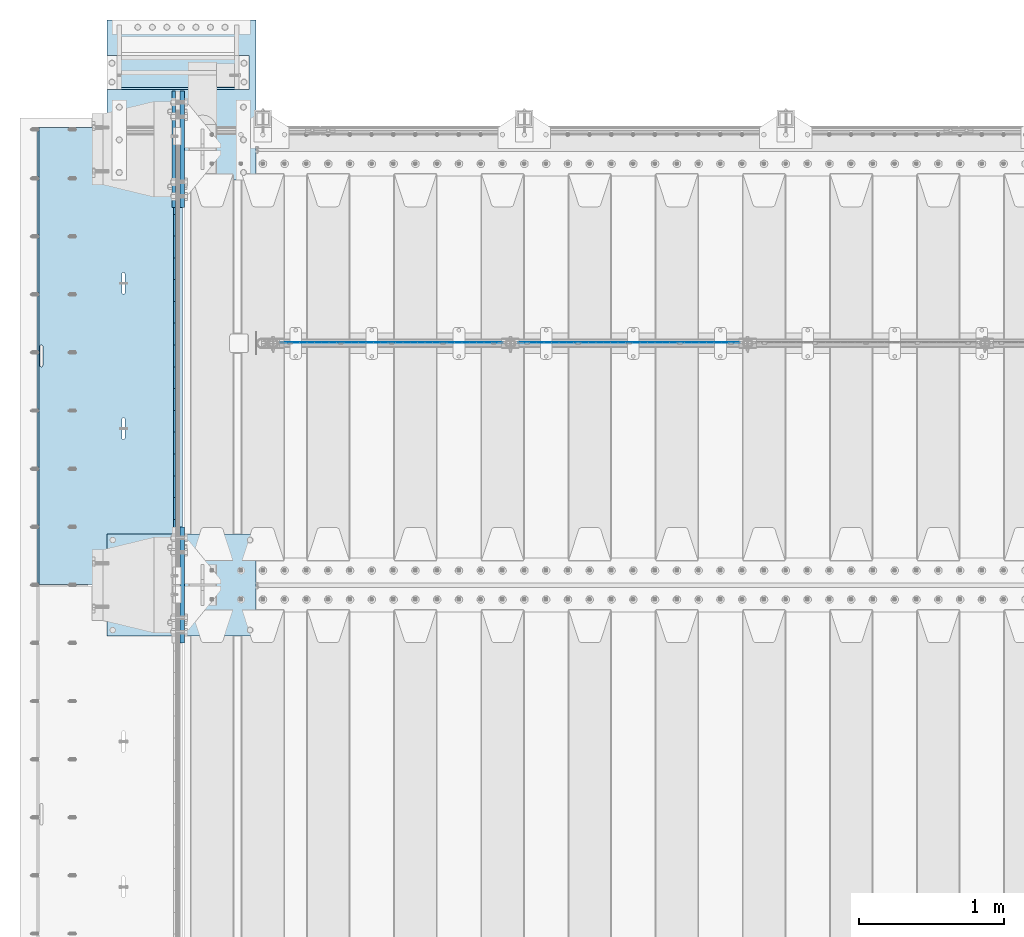
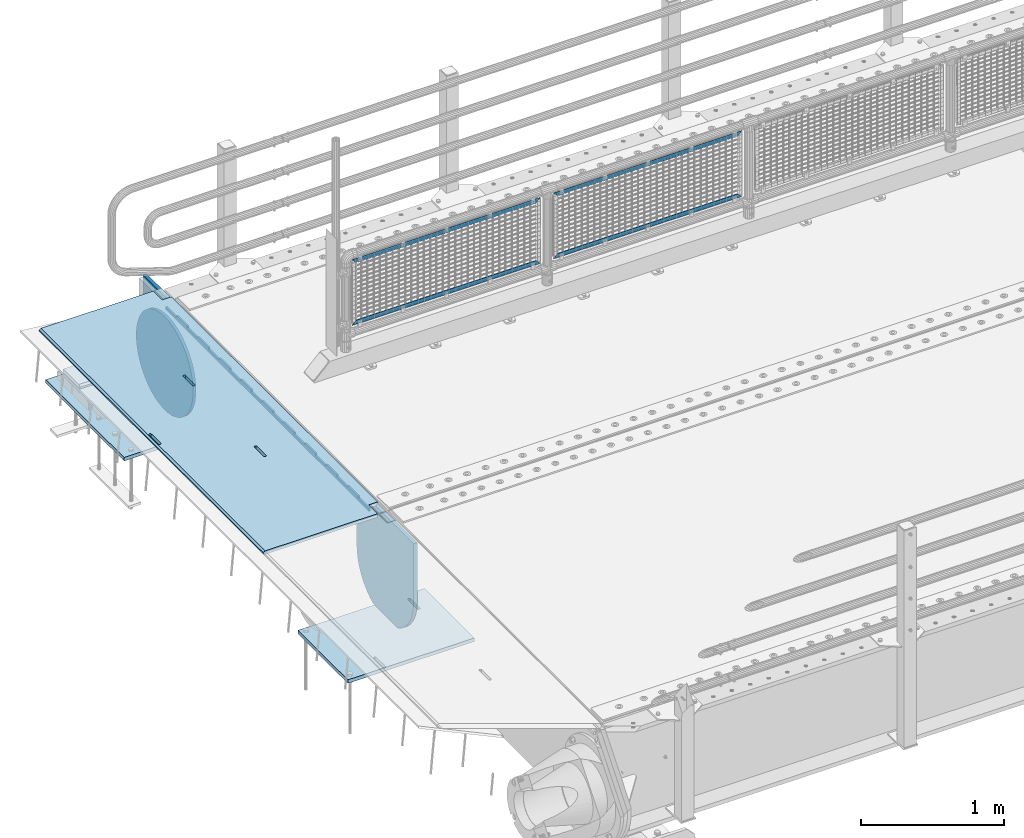
# One storey, part 192 of 242: 12 plates.
"""IFC2X3 building model written with IfcOpenShell, lengths in millimetres."""

from ifc_helpers import new_model, si_unit, frame, origin_with_axes, place, context, subcontext, project, spatial, faceted_brep, material, type_object, element, save


model = new_model("IFC2X3")

# Units and contexts
model_context = context("Model", 3, precision=1e-05, world=origin_with_axes())
body_context = subcontext(model_context, "Body", "Model", "MODEL_VIEW")
ifc_project = project(units=[si_unit("LENGTHUNIT", "METRE", prefix="MILLI"), si_unit("AREAUNIT", "SQUARE_METRE"), si_unit("VOLUMEUNIT", "CUBIC_METRE"), si_unit("MASSUNIT", "GRAM", prefix="KILO"), si_unit("TIMEUNIT", "SECOND"), si_unit("PLANEANGLEUNIT", "RADIAN"), si_unit("SOLIDANGLEUNIT", "STERADIAN"), si_unit("THERMODYNAMICTEMPERATUREUNIT", "DEGREE_CELSIUS"), si_unit("LUMINOUSINTENSITYUNIT", "LUMEN")], contexts=[model_context])

# Site, building, storey
site_placement = place(None, origin_with_axes())
site = spatial("IfcSite", under=ifc_project, at=site_placement, CompositionType="ELEMENT")
building_placement = place(site_placement, origin_with_axes())
building = spatial("IfcBuilding", under=site, at=building_placement, Name="Standard", CompositionType="ELEMENT")
storey_placement = place(building_placement, origin_with_axes())
storey = spatial("IfcBuildingStorey", under=building, at=storey_placement, Name="Undefined", CompositionType="ELEMENT", Elevation=0.0)

# Plates
ifc_material_1 = material(Name="STEEL/S355N")
plate_type_1 = type_object("IfcPlateType", PredefinedType="NOTDEFINED")
plate_1_placement = place(storey_placement, frame((-42455.0037545708, -17850.0000738706, -0.984391683580506), z_axis=(1.0000003385235e-09, -0.999999999987744, -4.95099999993936e-06), x_axis=(-0.999999999879068, -1.00000022173606e-09, -1.55519999981193e-05)))
element("IfcPlate", 1, at=plate_1_placement, inside=storey, type_object=plate_type_1, material=ifc_material_1, context=body_context, shape_type="Brep", body=[
    faceted_brep([(14.9998601691696, 15.0, 125.000024820823), (-0.000294611323624849, -0.000806902962788264, 124.999936248623), (-0.00191941575758392, 0.000806844426834791, 3020.00000492302), (14.9966216875182, 15.0, 3020.00007976651), (999.996459960938, 5.0, 0.0), (984.996459960945, 15.0, 3.63797880709171e-12), (984.996459718794, 15.0, 3145.0), (999.996459718786, 5.0, 3145.0), (984.99645996136, -15.0, 3.63797880709171e-12), (999.996459960938, -4.99999999999848, 0.0), (999.996459718786, -4.99999999999849, 3145.0), (984.996459719208, -15.0, 3145.0), (394.996621833991, -14.9999999992854, 1137.49999999811), (394.996621833998, 15.0, 1137.4999999981), (395.486056670808, 15.0, 1140.59016994185), (395.486056670801, -14.9999999992867, 1140.59016994185), (396.906451889779, 15.0, 1143.37785252103), (396.906451889779, -14.9999999992902, 1143.37785252103), (399.118769310437, 15.0, 1145.59016994186), (399.118769310437, -14.9999999992955, 1145.59016994186), (401.906451889503, 15.0, 1147.01056516106), (401.90645188951, -14.999999999302, 1147.01056516106), (404.996621833212, 15.0, 1147.4999999981), (404.996621833212, -14.9999999993092, 1147.49999999811), (408.086791776994, 15.0, 1147.01056516106), (408.086791776994, -14.9999999993163, 1147.01056516106), (410.874474356286, 15.0, 1145.59016994186), (410.874474356286, -14.9999999993227, 1145.59016994186), (413.086791777278, 15.0, 1143.37785252103), (413.086791777278, -14.9999999993277, 1143.37785252103), (414.5071869967, 15.0, 1140.59016994185), (414.507186996707, -14.9999999993308, 1140.59016994185), (414.996621833976, 15.0, 1137.49999999809), (414.996621833976, -14.9999999993318, 1137.4999999981), (414.996621843893, 15.0, 1007.4999999981), (414.996621843893, -14.9999999993243, 1007.4999999981), (414.507187007082, 15.0, 1004.40983005435), (414.50718700709, -14.999999999323, 1004.40983005435), (413.086791788097, 15.0, 1001.62214747518), (413.086791788097, -14.9999999993196, 1001.62214747518), (410.87447436744, 15.0, 999.409830054356), (410.87447436744, -14.9999999993143, 999.409830054356), (408.086791788373, 15.0, 997.989434835152), (408.086791788373, -14.9999999993078, 997.989434835155), (404.996621844781, 15.0, 997.499999998108), (404.996621844781, -14.9999999993006, 997.499999998108), (401.906451900992, 15.0, 997.989434835155), (401.906451900999, -14.9999999992934, 997.989434835155), (399.1187693217, 15.0, 999.409830054356), (399.118769321707, -14.9999999992871, 999.409830054356), (396.906451900715, 15.0, 1001.62214747518), (396.906451900715, -14.999999999282, 1001.62214747518), (395.486056681293, 15.0, 1004.40983005435), (395.486056681293, -14.9999999992789, 1004.40983005436), (394.99662184401, 15.0, 1007.4999999981), (394.99662184401, -14.999999999278, 1007.49999999811), (960.486056642803, -15.0000000006174, 1504.4098300541), (960.486056642803, 15.0, 1504.4098300541), (959.99662180552, 15.0, 1507.49999999785), (959.99662180552, -15.0000000006165, 1507.49999999785), (961.906451862218, -15.0000000006206, 1501.62214747493), (961.906451862218, 15.0, 1501.62214747493), (964.118769283217, -15.0000000006256, 1499.4098300541), (964.11876928321, 15.0, 1499.4098300541), (966.906451862502, -15.0000000006319, 1497.9894348349), (966.906451862495, 15.0, 1497.9894348349), (969.996621806284, -15.0000000006391, 1497.49999999785), (969.996621806284, 15.0, 1497.49999999785), (973.086791749884, -15.0000000006463, 1497.9894348349), (973.086791749884, 15.0, 1497.9894348349), (975.874474328943, -15.0000000006528, 1499.4098300541), (975.874474328943, 15.0, 1499.4098300541), (978.0867917496, -15.0000000006581, 1501.62214747492), (978.0867917496, 15.0, 1501.62214747492), (979.507186968593, -15.0000000006615, 1504.4098300541), (979.507186968585, 15.0, 1504.4098300541), (979.996621805403, -15.0000000006628, 1507.49999999784), (979.996621805403, 15.0, 1507.49999999784), (979.996621795486, -15.0000000006703, 1637.49999999784), (979.996621795486, 15.0, 1637.49999999784), (979.50718695821, -15.0000000006694, 1640.5901699416), (979.507186958203, 15.0, 1640.5901699416), (978.086791738788, -15.0000000006662, 1643.37785252077), (978.086791738788, 15.0, 1643.37785252077), (975.874474317789, -15.0000000006612, 1645.5901699416), (975.874474317789, 15.0, 1645.5901699416), (973.086791738504, -15.0000000006549, 1647.01056516081), (973.086791738504, 15.0, 1647.01056516081), (969.996621794708, -15.0000000006477, 1647.49999999785), (969.996621794715, 15.0, 1647.49999999785), (966.906451851013, -15.0000000006405, 1647.0105651608), (966.906451851006, 15.0, 1647.0105651608), (964.118769271947, -15.000000000634, 1645.5901699416), (964.118769271947, 15.0, 1645.5901699416), (961.90645185129, -15.0000000006287, 1643.37785252078), (961.90645185129, 15.0, 1643.37785252078), (960.486056632304, -15.0000000006253, 1640.5901699416), (960.486056632304, 15.0, 1640.5901699416), (959.996621795493, -15.000000000624, 1637.49999999785), (959.996621795493, 15.0, 1637.49999999785), (-0.000449375176685862, -14.9999999951863, 124.999861417735), (-0.000460362061858177, -15.00000004538, 3019.99993008589), (74.9964039659026, -14.999999998652, 3019.9999301541), (74.9968705259016, 15.0, 3020.0000798241), (74.9962640910162, -15.0, 3145.0), (74.9967306510152, 15.0, 3145.0), (74.9997820616045, -15.0, 3.63797880709171e-12), (75.0002485915975, 15.0, 0.0), (74.9996421867036, -15.0, 124.999930084094), (75.0001087167111, 15.0, 125.000079754092), (395.4860565938, -15.0000000032097, 2140.59016994137), (396.906451812785, -15.0000000031847, 2143.37785252055), (399.118769233435, -15.0000000031445, 2145.59016994137), (401.906451812509, -15.0000000030931, 2147.01056516058), (404.996621756211, -15.0000000030354, 2147.49999999762), (408.0867917, -15.0000000029771, 2147.01056516058), (410.874474279277, -15.000000002924, 2145.59016994137), (413.086791700283, -15.0000000028812, 2143.37785252055), (414.507186919698, -15.0000000028529, 2140.59016994136), (414.996621756974, -15.000000002842, 2137.49999999761), (414.996621766892, -15.0000000027658, 2007.49999999761), (414.507186930088, -15.0000000027732, 2004.40983005387), (413.086791711088, -15.0000000027982, 2001.6221474747), (410.874474290438, -15.0000000028384, 1999.40983005387), (408.086791711372, -15.0000000028898, 1997.98943483467), (404.996621767779, -15.0000000029475, 1997.49999999762), (401.90645182399, -15.0000000030057, 1997.98943483468), (399.118769244713, -15.0000000030589, 1999.40983005387), (396.906451823714, -15.0000000031016, 2001.6221474747), (395.486056604299, -15.0000000031299, 2004.40983005387), (394.996621767008, -15.0000000031409, 2007.49999999762), (394.996621756989, -15.0000000032171, 2137.49999999762), (396.906451823714, 15.0, 2001.6221474747), (395.486056604299, 15.0, 2004.40983005387), (399.118769244706, 15.0, 1999.40983005387), (401.906451823983, 15.0, 1997.98943483467), (404.996621767779, 15.0, 1997.49999999762), (408.086791711372, 15.0, 1997.98943483467), (410.874474290446, 15.0, 1999.40983005387), (413.086791711095, 15.0, 2001.62214747469), (414.507186930081, 15.0, 2004.40983005386), (414.996621766892, 15.0, 2007.49999999761), (414.996621756974, 15.0, 2137.49999999761), (414.507186919691, 15.0, 2140.59016994136), (413.086791700283, 15.0, 2143.37785252055), (410.874474279284, 15.0, 2145.59016994137), (408.0867917, 15.0, 2147.01056516057), (404.996621756211, 15.0, 2147.49999999762), (401.906451812501, 15.0, 2147.01056516057), (399.118769233435, 15.0, 2145.59016994137), (396.906451812785, 15.0, 2143.37785252055), (395.4860565938, 15.0, 2140.59016994137), (394.996621756989, 15.0, 2137.49999999762), (394.996621767008, 15.0, 2007.49999999762)], [[[0, 1, 2, 3]], [[4, 5, 6, 7]], [[8, 9, 10, 11]], [[12, 13, 14, 15]], [[15, 14, 16, 17]], [[17, 16, 18, 19]], [[19, 18, 20, 21]], [[21, 20, 22, 23]], [[23, 22, 24, 25]], [[25, 24, 26, 27]], [[27, 26, 28, 29]], [[29, 28, 30, 31]], [[31, 30, 32, 33]], [[33, 32, 34, 35]], [[35, 34, 36, 37]], [[37, 36, 38, 39]], [[39, 38, 40, 41]], [[41, 40, 42, 43]], [[43, 42, 44, 45]], [[45, 44, 46, 47]], [[47, 46, 48, 49]], [[49, 48, 50, 51]], [[51, 50, 52, 53]], [[53, 52, 54, 55]], [[55, 54, 13, 12]], [[56, 57, 58, 59]], [[60, 61, 57, 56]], [[62, 63, 61, 60]], [[64, 65, 63, 62]], [[66, 67, 65, 64]], [[68, 69, 67, 66]], [[70, 71, 69, 68]], [[72, 73, 71, 70]], [[74, 75, 73, 72]], [[76, 77, 75, 74]], [[78, 79, 77, 76]], [[80, 81, 79, 78]], [[82, 83, 81, 80]], [[84, 85, 83, 82]], [[86, 87, 85, 84]], [[88, 89, 87, 86]], [[90, 91, 89, 88]], [[92, 93, 91, 90]], [[94, 95, 93, 92]], [[96, 97, 95, 94]], [[98, 99, 97, 96]], [[59, 58, 99, 98]], [[100, 101, 2, 1]], [[101, 102, 103, 3, 2]], [[104, 105, 103, 102]], [[7, 6, 105, 104, 11, 10]], [[4, 7, 10, 9]], [[106, 107, 5, 4, 9, 8]], [[106, 108, 109, 107]], [[109, 108, 100, 1, 0]], [[104, 102, 101, 100, 108, 106, 8, 11], [15, 17, 19, 21, 23, 25, 27, 29, 31, 33, 35, 37, 39, 41, 43, 45, 47, 49, 51, 53, 55, 12], [96, 94, 92, 90, 88, 86, 84, 82, 80, 78, 76, 74, 72, 70, 68, 66, 64, 62, 60, 56, 59, 98], [110, 111, 112, 113, 114, 115, 116, 117, 118, 119, 120, 121, 122, 123, 124, 125, 126, 127, 128, 129, 130, 131]], [[128, 132, 133, 129]], [[127, 134, 132, 128]], [[126, 135, 134, 127]], [[125, 136, 135, 126]], [[124, 137, 136, 125]], [[123, 138, 137, 124]], [[122, 139, 138, 123]], [[121, 140, 139, 122]], [[120, 141, 140, 121]], [[119, 142, 141, 120]], [[118, 143, 142, 119]], [[117, 144, 143, 118]], [[116, 145, 144, 117]], [[115, 146, 145, 116]], [[114, 147, 146, 115]], [[113, 148, 147, 114]], [[112, 149, 148, 113]], [[111, 150, 149, 112]], [[110, 151, 150, 111]], [[131, 152, 151, 110]], [[130, 153, 152, 131]], [[129, 133, 153, 130]], [[107, 109, 0, 3, 103, 105, 6, 5], [50, 48, 46, 44, 42, 40, 38, 36, 34, 32, 30, 28, 26, 24, 22, 20, 18, 16, 14, 13, 54, 52], [132, 134, 135, 136, 137, 138, 139, 140, 141, 142, 143, 144, 145, 146, 147, 148, 149, 150, 151, 152, 153, 133], [61, 63, 65, 67, 69, 71, 73, 75, 77, 79, 81, 83, 85, 87, 89, 91, 93, 95, 97, 99, 58, 57]]]),
])
plate_type_2 = type_object("IfcPlateType", PredefinedType="NOTDEFINED")
plate_2_placement = place(storey_placement, frame((-42507.5, -17997.4999006275, -35.9858217417067), z_axis=(1.0000003385235e-09, -0.999999999987744, -4.95099999993936e-06), x_axis=(0.0, 4.95100000930962e-06, -0.999999999987744)))
element("IfcPlate", 2, at=plate_2_placement, inside=storey, type_object=plate_type_2, material=ifc_material_1, context=body_context, shape_type="Brep", body=[
    faceted_brep([(-7.105427357601e-15, -7.5, 3.63797880709171e-12), (8.68283223098842e-12, -7.5, 150.000000000004), (8.68283223098842e-12, 7.5, 150.000000000004), (-7.105427357601e-15, 7.5, 3.63797880709171e-12), (-14.9999999999986, -7.5, 150.0), (-14.9999999999986, 7.5, 150.0), (-14.9999999999972, -7.5, 300.000000000004), (-14.9999999999972, 7.5, 300.000000000004), (1.55324642037158e-11, -7.5, 300.000000000004), (1.55324642037158e-11, 7.5, 300.000000000004), (1.87654336514242e-11, -7.5, 450.000000000004), (1.87654336514242e-11, 7.5, 450.000000000004), (-14.9999999999958, -7.5, 450.000000000004), (-14.9999999999958, 7.5, 450.000000000004), (-14.9999999999944, -7.5, 600.0), (-14.9999999999944, 7.5, 600.0), (2.74411604550551e-11, -7.5, 600.000000000004), (2.74411604550551e-11, 7.5, 600.000000000004), (3.24860138789518e-11, -7.5, 750.000000000004), (3.24860138789518e-11, 7.5, 750.000000000004), (-14.999999999993, -7.5, 750.000000000004), (-14.999999999993, 7.5, 750.000000000004), (-14.9999999999916, -7.5, 900.000000000007), (-14.9999999999916, 7.5, 900.000000000007), (4.11688461099402e-11, -7.5, 900.000000000004), (4.11688461099402e-11, 7.5, 900.000000000004), (4.62136995338369e-11, -7.5, 1050.0), (4.62136995338369e-11, 7.5, 1050.0), (-14.9999999999902, -7.5, 1050.0), (-14.9999999999902, 7.5, 1050.0), (-14.9999999999888, -7.5, 1200.0), (-14.9999999999888, 7.5, 1200.0), (5.30775423612795e-11, -7.5, 1200.0), (5.30775423612795e-11, 7.5, 1200.0), (5.99413851887221e-11, -7.5, 1350.0), (5.99413851887221e-11, 7.5, 1350.0), (-14.9999999999874, -7.5, 1350.00000000001), (-14.9999999999874, 7.5, 1350.00000000001), (-14.9999999999859, -7.5, 1500.0), (-14.9999999999859, 7.5, 1500.0), (6.49791331852612e-11, -7.5, 1500.0), (6.49791331852612e-11, 7.5, 1500.0), (7.36690708436072e-11, -7.5, 1650.0), (7.36690708436072e-11, 7.5, 1650.0), (-14.9999999999845, -7.5, 1650.0), (-14.9999999999845, 7.5, 1650.0), (-14.9999999999831, -7.5, 1800.00000000001), (-14.9999999999831, 7.5, 1800.00000000001), (7.68878294366004e-11, -7.5, 1800.0), (7.68878294366004e-11, 7.5, 1800.0), (8.3751672264043e-11, -7.5, 1950.0), (8.3751672264043e-11, 7.5, 1950.0), (-14.9999999999817, -7.5, 1950.0), (-14.9999999999817, 7.5, 1950.0), (-14.9999999999803, -7.5, 2100.0), (-14.9999999999803, 7.5, 2100.0), (9.06226205188432e-11, -7.5, 2100.0), (9.06226205188432e-11, 7.5, 2100.0), (9.56603685153823e-11, -7.5, 2250.00000000001), (9.56603685153823e-11, 7.5, 2250.00000000001), (-14.9999999999789, -7.5, 2250.00000000001), (-14.9999999999789, 7.5, 2250.00000000001), (-14.9999999999775, -7.5, 2400.0), (-14.9999999999775, 7.5, 2400.0), (1.04343200746371e-10, -7.5, 2400.0), (1.04343200746371e-10, 7.5, 2400.0), (1.0938094874291e-10, -7.5, 2550.0), (1.0938094874291e-10, 7.5, 2550.0), (-14.9999999999761, -7.5, 2550.0), (-14.9999999999761, 7.5, 2550.0), (-14.9999999999747, -7.5, 2700.00000000001), (-14.9999999999747, 7.5, 2700.00000000001), (1.14432907594164e-10, -7.5, 2700.00000000001), (1.14432907594164e-10, 7.5, 2700.00000000001), (1.23108634397795e-10, -7.5, 2850.0), (1.23108634397795e-10, 7.5, 2850.0), (25.0000000000267, -7.5, 2850.0), (25.0000000000267, 7.5, 2850.0), (25.0, -7.5, 3.63797880709171e-12), (25.0, 7.5, 3.63797880709171e-12)], [[[0, 1, 2, 3]], [[1, 4, 5, 2]], [[4, 6, 7, 5]], [[6, 8, 9, 7]], [[8, 10, 11, 9]], [[10, 12, 13, 11]], [[12, 14, 15, 13]], [[14, 16, 17, 15]], [[16, 18, 19, 17]], [[18, 20, 21, 19]], [[20, 22, 23, 21]], [[22, 24, 25, 23]], [[24, 26, 27, 25]], [[26, 28, 29, 27]], [[28, 30, 31, 29]], [[30, 32, 33, 31]], [[32, 34, 35, 33]], [[34, 36, 37, 35]], [[36, 38, 39, 37]], [[38, 40, 41, 39]], [[40, 42, 43, 41]], [[42, 44, 45, 43]], [[44, 46, 47, 45]], [[46, 48, 49, 47]], [[48, 50, 51, 49]], [[50, 52, 53, 51]], [[52, 54, 55, 53]], [[54, 56, 57, 55]], [[56, 58, 59, 57]], [[58, 60, 61, 59]], [[60, 62, 63, 61]], [[62, 64, 65, 63]], [[64, 66, 67, 65]], [[66, 68, 69, 67]], [[68, 70, 71, 69]], [[70, 72, 73, 71]], [[72, 74, 75, 73]], [[74, 76, 77, 75]], [[76, 78, 79, 77]], [[78, 0, 3, 79]], [[5, 7, 9, 11, 13, 15, 17, 19, 21, 23, 25, 27, 29, 31, 33, 35, 37, 39, 41, 43, 45, 47, 49, 51, 53, 55, 57, 59, 61, 63, 65, 67, 69, 71, 73, 75, 77, 79, 3, 2]], [[78, 76, 74, 72, 70, 68, 66, 64, 62, 60, 58, 56, 54, 52, 50, 48, 46, 44, 42, 40, 38, 36, 34, 32, 30, 28, 26, 24, 22, 20, 18, 16, 14, 12, 10, 8, 6, 4, 1, 0]]]),
])
ifc_material_2 = material(Name="Misc_Undefined")
plate_type_3 = type_object("IfcPlateType", PredefinedType="NOTDEFINED")
plate_3_placement = place(storey_placement, frame((-40142.4949882696, -19329.5, 351.520303374641), z_axis=(0.0, 0.0, 1.0), x_axis=(1.0, 0.0, 0.0)))
element("IfcPlate", 3, at=plate_3_placement, inside=storey, type_object=plate_type_3, material=ifc_material_2, context=body_context, shape_type="Brep", body=[
    faceted_brep([(0.0, -1.50000000000364, 0.0), (35.0002975463867, -1.5, 34.9996948242188), (35.0002975463867, 1.5, 34.9996948242188), (-3.63797880709171e-12, 1.49999999999636, 0.0), (1490.99035644531, -1.5, 34.9999923706055), (1490.99035644531, 1.5, 34.9999923706055), (1525.98999023438, -1.5, 2.81374923361e-11), (1525.98999023438, 1.5, 2.81374923361e-11)], [[[0, 1, 2, 3]], [[1, 4, 5, 2]], [[4, 6, 7, 5]], [[6, 0, 3, 7]], [[5, 7, 3, 2]], [[6, 4, 1, 0]]]),
])
plate_4_placement = place(storey_placement, frame((-38616.4999998124, -19329.5, 914.520000175701), z_axis=(-0.707103624179499, 0.0, 0.707109938179501), x_axis=(-0.707109938179495, 0.0, -0.707103624179505)))
element("IfcPlate", 4, at=plate_4_placement, inside=storey, type_object=plate_type_3, material=ifc_material_2, context=body_context, shape_type="Brep", body=[
    faceted_brep([(0.0, -1.50000000000364, 0.0), (1079.04980468751, -1.5, 1079.04028320313), (1079.04980468751, 1.5, 1079.04028320313), (-3.63797880709171e-12, 1.49999999999636, 0.0), (1079.04272460939, -1.5, 1029.53576660157), (1079.04272460939, 1.5, 1029.53576660157), (49.4976959228534, -1.5, -3.63797880709171e-12), (49.4976959228534, 1.5, -3.63797880709171e-12)], [[[0, 1, 2, 3]], [[1, 4, 5, 2]], [[4, 6, 7, 5]], [[6, 0, 3, 7]], [[5, 7, 3, 2]], [[6, 4, 1, 0]]]),
])
plate_5_placement = place(storey_placement, frame((-41775.4949882696, -19329.5, 351.520303374641), z_axis=(0.0, 0.0, 1.0), x_axis=(1.0, 0.0, 0.0)))
element("IfcPlate", 5, at=plate_5_placement, inside=storey, type_object=plate_type_3, material=ifc_material_2, context=body_context, shape_type="Brep", body=[
    faceted_brep([(0.0, -1.50000000000364, 0.0), (35.0002975463867, -1.5, 34.9996948242188), (35.0002975463867, 1.5, 34.9996948242188), (-3.63797880709171e-12, 1.49999999999636, 0.0), (1490.99035644531, -1.5, 34.9999923706055), (1490.99035644531, 1.5, 34.9999923706055), (1525.98999023438, -1.5, 2.81374923361e-11), (1525.98999023438, 1.5, 2.81374923361e-11)], [[[0, 1, 2, 3]], [[1, 4, 5, 2]], [[4, 6, 7, 5]], [[6, 0, 3, 7]], [[5, 7, 3, 2]], [[6, 4, 1, 0]]]),
])
plate_6_placement = place(storey_placement, frame((-40249.4999998124, -19329.5, 914.520000175701), z_axis=(-0.707103624179499, 0.0, 0.707109938179501), x_axis=(-0.707109938179495, 0.0, -0.707103624179505)))
element("IfcPlate", 6, at=plate_6_placement, inside=storey, type_object=plate_type_3, material=ifc_material_2, context=body_context, shape_type="Brep", body=[
    faceted_brep([(0.0, -1.50000000000364, 0.0), (1079.04980468751, -1.5, 1079.04028320313), (1079.04980468751, 1.5, 1079.04028320313), (-3.63797880709171e-12, 1.49999999999636, 0.0), (1079.04272460939, -1.5, 1029.53576660157), (1079.04272460939, 1.5, 1029.53576660157), (49.4976959228534, -1.5, -3.63797880709171e-12), (49.4976959228534, 1.5, -3.63797880709171e-12)], [[[0, 1, 2, 3]], [[1, 4, 5, 2]], [[4, 6, 7, 5]], [[6, 0, 3, 7]], [[5, 7, 3, 2]], [[6, 4, 1, 0]]]),
])
plate_type_4 = type_object("IfcPlateType", PredefinedType="NOTDEFINED")
plate_7_placement = place(storey_placement, frame((-42455.0, -18400.0, -20.0), z_axis=(0.0, 1.0, 0.0), x_axis=(0.0, 0.0, -1.0)))
element("IfcPlate", 7, at=plate_7_placement, inside=storey, type_object=plate_type_4, material=ifc_material_1, context=body_context, shape_type="Brep", body=[
    faceted_brep([(855.0, -15.0, 572.963114670041), (855.0, 15.0, 572.963114670041), (849.182410260924, 15.0, 585.889268816907), (849.182410260924, -15.0, 585.889268816907), (824.193546357181, 15.0, 627.22589869189), (824.193546357181, -15.0, 627.22589869189), (794.404299268241, 15.0, 665.249063295789), (794.404299268241, -15.0, 665.249063295789), (760.249063296205, 15.0, 699.404299267968), (760.249063296205, -15.0, 699.404299267968), (722.225898692439, 15.0, 729.193546357052), (722.225898692439, -15.0, 729.193546357052), (680.889268817575, 15.0, 754.182410260939), (680.889268817575, -15.0, 754.182410260939), (636.841954817181, 15.0, 774.006497073897), (636.841954817181, -15.0, 774.006497073897), (590.726265715288, 15.0, 788.376726970229), (590.726265715288, -15.0, 788.376726970229), (543.214672102496, 15.0, 797.083549639108), (543.214672102496, -15.0, 797.083549639108), (495.0, -15.0, 800.000000000029), (495.0, 15.0, 800.0), (494.999999999412, -15.0, 0.0), (494.999999999412, 15.0, 0.0), (543.21467210319, 15.0, 2.91645036481714), (543.21467210319, -15.0, 2.91645036481714), (590.726265715857, 15.0, 11.6232730332849), (590.726265715857, -15.0, 11.6232730332849), (636.841954817646, 15.0, 25.9935029291846), (636.841954817646, -15.0, 25.9935029291846), (680.889268817962, 15.0, 45.817589741695), (680.889268817962, -15.0, 45.817589741695), (722.225898692766, 15.0, 70.8064536451311), (722.225898692766, -15.0, 70.8064536451311), (760.249063296498, 15.0, 100.595700733757), (760.249063296498, -15.0, 100.595700733757), (794.404299268526, 15.0, 134.750936705481), (794.404299268526, -15.0, 134.750936705481), (824.193546357479, 15.0, 172.77410130894), (824.193546357479, -15.0, 172.77410130894), (849.182410261259, 15.0, 214.110731183497), (849.182410261259, -15.0, 214.110731183497), (855.0, -15.0, 227.03688532946), (855.0, 15.0, 227.03688532946), (0.0, -15.0, 0.0), (0.0, 15.0, 0.0), (0.0, 15.0, 800.0), (0.0, -15.0, 800.0)], [[[0, 1, 2, 3]], [[3, 2, 4, 5]], [[5, 4, 6, 7]], [[7, 6, 8, 9]], [[9, 8, 10, 11]], [[11, 10, 12, 13]], [[13, 12, 14, 15]], [[15, 14, 16, 17]], [[17, 16, 18, 19]], [[20, 19, 18, 21]], [[22, 23, 24, 25]], [[25, 24, 26, 27]], [[27, 26, 28, 29]], [[29, 28, 30, 31]], [[31, 30, 32, 33]], [[33, 32, 34, 35]], [[35, 34, 36, 37]], [[37, 36, 38, 39]], [[39, 38, 40, 41]], [[42, 41, 40, 43]], [[42, 43, 1, 0]], [[44, 45, 23, 22]], [[16, 14, 12, 10, 8, 6, 4, 2, 1, 43, 40, 38, 36, 34, 32, 30, 28, 26, 24, 23, 45, 46, 21, 18]], [[44, 47, 46, 45]], [[46, 47, 20, 21]], [[47, 44, 22, 25, 27, 29, 31, 33, 35, 37, 39, 41, 42, 0, 3, 5, 7, 9, 11, 13, 15, 17, 19, 20]]]),
])
plate_8_placement = place(storey_placement, frame((-42455.0, -21400.0, -20.0), z_axis=(0.0, 1.0, 0.0), x_axis=(0.0, 0.0, -1.0)))
element("IfcPlate", 8, at=plate_8_placement, inside=storey, type_object=plate_type_4, material=ifc_material_1, context=body_context, shape_type="Brep", body=[
    faceted_brep([(855.0, -15.0, 572.963114670041), (855.0, 15.0, 572.963114670041), (849.182410260924, 15.0, 585.889268816907), (849.182410260924, -15.0, 585.889268816907), (824.193546357181, 15.0, 627.22589869189), (824.193546357181, -15.0, 627.22589869189), (794.404299268241, 15.0, 665.249063295789), (794.404299268241, -15.0, 665.249063295789), (760.249063296205, 15.0, 699.404299267968), (760.249063296205, -15.0, 699.404299267968), (722.225898692439, 15.0, 729.193546357052), (722.225898692439, -15.0, 729.193546357052), (680.889268817575, 15.0, 754.182410260939), (680.889268817575, -15.0, 754.182410260939), (636.841954817181, 15.0, 774.006497073897), (636.841954817181, -15.0, 774.006497073897), (590.726265715288, 15.0, 788.376726970229), (590.726265715288, -15.0, 788.376726970229), (543.214672102496, 15.0, 797.083549639108), (543.214672102496, -15.0, 797.083549639108), (495.0, -15.0, 800.000000000029), (495.0, 15.0, 800.0), (494.999999999412, -15.0, 0.0), (494.999999999412, 15.0, 0.0), (543.21467210319, 15.0, 2.91645036481714), (543.21467210319, -15.0, 2.91645036481714), (590.726265715857, 15.0, 11.6232730332849), (590.726265715857, -15.0, 11.6232730332849), (636.841954817646, 15.0, 25.9935029291846), (636.841954817646, -15.0, 25.9935029291846), (680.889268817962, 15.0, 45.817589741695), (680.889268817962, -15.0, 45.817589741695), (722.225898692766, 15.0, 70.8064536451311), (722.225898692766, -15.0, 70.8064536451311), (760.249063296498, 15.0, 100.595700733757), (760.249063296498, -15.0, 100.595700733757), (794.404299268526, 15.0, 134.750936705481), (794.404299268526, -15.0, 134.750936705481), (824.193546357479, 15.0, 172.77410130894), (824.193546357479, -15.0, 172.77410130894), (849.182410261259, 15.0, 214.110731183497), (849.182410261259, -15.0, 214.110731183497), (855.0, -15.0, 227.03688532946), (855.0, 15.0, 227.03688532946), (0.0, -15.0, 0.0), (0.0, 15.0, 0.0), (0.0, 15.0, 800.0), (0.0, -15.0, 800.0)], [[[0, 1, 2, 3]], [[3, 2, 4, 5]], [[5, 4, 6, 7]], [[7, 6, 8, 9]], [[9, 8, 10, 11]], [[11, 10, 12, 13]], [[13, 12, 14, 15]], [[15, 14, 16, 17]], [[17, 16, 18, 19]], [[20, 19, 18, 21]], [[22, 23, 24, 25]], [[25, 24, 26, 27]], [[27, 26, 28, 29]], [[29, 28, 30, 31]], [[31, 30, 32, 33]], [[33, 32, 34, 35]], [[35, 34, 36, 37]], [[37, 36, 38, 39]], [[39, 38, 40, 41]], [[42, 41, 40, 43]], [[42, 43, 1, 0]], [[44, 45, 23, 22]], [[16, 14, 12, 10, 8, 6, 4, 2, 1, 43, 40, 38, 36, 34, 32, 30, 28, 26, 24, 23, 45, 46, 21, 18]], [[44, 47, 46, 45]], [[46, 47, 20, 21]], [[47, 44, 22, 25, 27, 29, 31, 33, 35, 37, 39, 41, 42, 0, 3, 5, 7, 9, 11, 13, 15, 17, 19, 20]]]),
])
plate_type_5 = type_object("IfcPlateType", PredefinedType="NOTDEFINED")
plate_9_placement = place(storey_placement, frame((-42512.5, -17600.0, -114.999999999998), z_axis=(0.0, 0.0, -1.0), x_axis=(0.0, -1.0, 0.0)))
element("IfcPlate", 9, at=plate_9_placement, inside=storey, type_object=plate_type_5, material=ifc_material_1, context=body_context, shape_type="Brep", body=[
    faceted_brep([(0.0, -12.5, 400.0), (2.91645036199043, -12.5, 448.214672101509), (2.91645036199043, 12.5, 448.214672101509), (0.0, 12.5, 400.0), (11.6232730309493, -12.5, 495.726265714256), (11.6232730309493, 12.5, 495.726265714256), (25.9935029273402, -12.5, 541.841954816098), (25.9935029273402, 12.5, 541.841954816098), (45.8175897403271, -12.5, 585.889268816447), (45.8175897403271, 12.5, 585.889268816447), (70.8064536442362, -12.5, 627.225898691268), (70.8064536442362, 12.5, 627.225898691268), (100.595700733313, -12.5, 665.249063295001), (100.595700733313, 12.5, 665.249063295001), (134.75093670547, -12.5, 699.404299267018), (134.75093670547, 12.5, 699.404299267018), (172.774101309336, -12.5, 729.193546355957), (172.774101309336, 12.5, 729.193546355957), (214.110731184279, -12.5, 754.182410259717), (214.110731184279, 12.5, 754.182410259717), (258.158045184744, -12.5, 774.006497072562), (258.158045184744, 12.5, 774.006497072562), (304.273734286689, -12.5, 788.376726968807), (304.273734286689, 12.5, 788.376726968807), (351.785327899524, -12.5, 797.083549637626), (351.785327899524, 12.5, 797.083549637626), (400.0, -12.5, 800.0), (400.0, 12.5, 800.0), (448.214672103393, -12.5, 797.083549638417), (448.214672103393, 12.5, 797.083549638417), (495.726265716065, -12.5, 788.376726969676), (495.726265716065, 12.5, 788.376726969676), (541.841954817828, -12.5, 774.006497073487), (541.841954817828, 12.5, 774.006497073487), (585.889268818089, -12.5, 754.182410260677), (585.889268818089, 12.5, 754.182410260677), (627.225898692814, -12.5, 729.193546356937), (627.225898692814, 12.5, 729.193546356937), (665.249063296429, -12.5, 699.404299268004), (665.249063296429, 12.5, 699.404299268004), (699.404299268321, -12.5, 665.249063295974), (699.404299268321, 12.5, 665.249063295974), (729.19354635711, -12.5, 627.225898692221), (729.19354635711, 12.5, 627.225898692221), (754.182410260706, -12.5, 585.889268817375), (754.182410260706, 12.5, 585.889268817375), (774.006497073366, -12.5, 541.841954817), (774.006497073366, 12.5, 541.841954817), (788.376726969411, -12.5, 495.726265715133), (788.376726969411, 12.5, 495.726265715133), (797.08354963801, -12.5, 448.214672102373), (797.08354963801, 12.5, 448.214672102373), (800.0, -12.5, 400.0), (800.0, 12.5, 400.0), (797.08354963802, -12.5, 351.785327898509), (797.08354963802, 12.5, 351.785327898509), (788.376726969058, -12.5, 304.273734285764), (788.376726969058, 12.5, 304.273734285764), (774.006497072671, -12.5, 258.158045183922), (774.006497072671, 12.5, 258.158045183922), (754.18241025968, -12.5, 214.110731183573), (754.18241025968, 12.5, 214.110731183573), (729.193546355775, -12.5, 172.774101308758), (729.193546355775, 12.5, 172.774101308758), (699.404299266695, -12.5, 134.750936705022), (699.404299266695, 12.5, 134.750936705022), (665.249063294537, -12.5, 100.595700733011), (665.249063294537, 12.5, 100.595700733011), (627.225898690671, -12.5, 70.8064536440761), (627.225898690671, 12.5, 70.8064536440761), (585.889268815728, -12.5, 45.817589740318), (585.889268815728, 12.5, 45.817589740318), (541.841954815267, -12.5, 25.9935029274748), (541.841954815267, 12.5, 25.9935029274748), (495.726265713321, -12.5, 11.6232730312331), (495.726265713321, 12.5, 11.6232730312331), (448.214672100487, -12.5, 2.91645036241607), (448.214672100487, 12.5, 2.91645036241607), (400.0, -12.5, -5.6843418860808e-14), (400.0, 12.5, -5.6843418860808e-14), (351.785327896621, -12.5, 2.91645036159753), (351.785327896621, 12.5, 2.91645036159753), (304.27373428395, -12.5, 11.6232730303418), (304.27373428395, 12.5, 11.6232730303418), (258.15804518219, -12.5, 25.9935029265289), (258.15804518219, 12.5, 25.9935029265289), (214.110731181929, -12.5, 45.8175897393394), (214.110731181929, 12.5, 45.8175897393394), (172.774101307208, -12.5, 70.8064536430811), (172.774101307208, 12.5, 70.8064536430811), (134.750936703589, -12.5, 100.595700732014), (134.750936703589, 12.5, 100.595700732014), (100.595700731697, -12.5, 134.750936704046), (100.595700731697, 12.5, 134.750936704046), (70.8064536429083, -12.5, 172.774101307798), (70.8064536429083, 12.5, 172.774101307798), (45.8175897393157, -12.5, 214.11073118264), (45.8175897393157, 12.5, 214.11073118264), (25.9935029266562, -12.5, 258.158045183016), (25.9935029266562, 12.5, 258.158045183016), (11.623273030611, -12.5, 304.273734284881), (11.623273030611, 12.5, 304.273734284881), (2.91645036201226, -12.5, 351.785327897642), (2.91645036201226, 12.5, 351.785327897642)], [[[0, 1, 2, 3]], [[1, 4, 5, 2]], [[4, 6, 7, 5]], [[6, 8, 9, 7]], [[8, 10, 11, 9]], [[10, 12, 13, 11]], [[12, 14, 15, 13]], [[14, 16, 17, 15]], [[16, 18, 19, 17]], [[18, 20, 21, 19]], [[20, 22, 23, 21]], [[22, 24, 25, 23]], [[24, 26, 27, 25]], [[26, 28, 29, 27]], [[28, 30, 31, 29]], [[30, 32, 33, 31]], [[32, 34, 35, 33]], [[34, 36, 37, 35]], [[36, 38, 39, 37]], [[38, 40, 41, 39]], [[40, 42, 43, 41]], [[42, 44, 45, 43]], [[44, 46, 47, 45]], [[46, 48, 49, 47]], [[48, 50, 51, 49]], [[50, 52, 53, 51]], [[52, 54, 55, 53]], [[54, 56, 57, 55]], [[56, 58, 59, 57]], [[58, 60, 61, 59]], [[60, 62, 63, 61]], [[62, 64, 65, 63]], [[64, 66, 67, 65]], [[66, 68, 69, 67]], [[68, 70, 71, 69]], [[70, 72, 73, 71]], [[72, 74, 75, 73]], [[74, 76, 77, 75]], [[76, 78, 79, 77]], [[78, 80, 81, 79]], [[80, 82, 83, 81]], [[82, 84, 85, 83]], [[84, 86, 87, 85]], [[86, 88, 89, 87]], [[88, 90, 91, 89]], [[90, 92, 93, 91]], [[92, 94, 95, 93]], [[94, 96, 97, 95]], [[96, 98, 99, 97]], [[98, 100, 101, 99]], [[100, 102, 103, 101]], [[102, 0, 3, 103]], [[5, 7, 9, 11, 13, 15, 17, 19, 21, 23, 25, 27, 29, 31, 33, 35, 37, 39, 41, 43, 45, 47, 49, 51, 53, 55, 57, 59, 61, 63, 65, 67, 69, 71, 73, 75, 77, 79, 81, 83, 85, 87, 89, 91, 93, 95, 97, 99, 101, 103, 3, 2]], [[102, 100, 98, 96, 94, 92, 90, 88, 86, 84, 82, 80, 78, 76, 74, 72, 70, 68, 66, 64, 62, 60, 58, 56, 54, 52, 50, 48, 46, 44, 42, 40, 38, 36, 34, 32, 30, 28, 26, 24, 22, 20, 18, 16, 14, 12, 10, 8, 6, 4, 1, 0]]]),
])
ifc_material_3 = material()
plate_type_6 = type_object("IfcPlateType", PredefinedType="NOTDEFINED")
plate_10_placement = place(storey_placement, frame((-41995.0000000011, -17355.0000000036, -813.000000000004), z_axis=(0.0, -1.0, 0.0), x_axis=(-1.0, 0.0, 0.0)))
element("IfcPlate", 10, at=plate_10_placement, inside=storey, type_object=plate_type_6, material=ifc_material_3, context=body_context, shape_type="Brep", body=[
    faceted_brep([(0.0, 0.0, 235.0), (0.0, -15.0, 220.0), (979.0, -15.0, 220.0), (979.0, 0.0, 235.0), (0.0, 15.0, 235.0), (0.0, 15.0, 0.0), (0.0, -15.0, 0.0), (979.0, 15.0, 235.0), (979.0, -15.0, 0.0), (979.0, 15.0, 0.0)], [[[0, 1, 2, 3]], [[4, 5, 6, 1, 0]], [[7, 4, 0, 3]], [[8, 9, 7, 3, 2]], [[8, 6, 5, 9]], [[7, 9, 5, 4]], [[6, 8, 2, 1]]]),
])
plate_type_7 = type_object("IfcPlateType", PredefinedType="NOTDEFINED")
plate_11_placement = place(storey_placement, frame((-42974.000000002, -17110.0, -1053.0), z_axis=(1.0, 0.0, 0.0), x_axis=(0.0, -1.0, 0.0)))
element("IfcPlate", 11, at=plate_11_placement, inside=storey, type_object=plate_type_7, material=ifc_material_3, context=body_context, shape_type="Brep", body=[
    faceted_brep([(0.0, -15.0, 0.0), (2.93249104288407e-06, -15.0, 1025.0), (2.93249104288407e-06, 15.0, 1025.0), (0.0, 15.0, 0.0), (1100.0, -15.0, 1025.0), (1100.0, 15.0, 1025.0), (1100.0, -15.0, -2.18278728425503e-11), (1100.0, 15.0, -2.18278728425503e-11)], [[[0, 1, 2, 3]], [[1, 4, 5, 2]], [[4, 6, 7, 5]], [[6, 0, 3, 7]], [[5, 7, 3, 2]], [[6, 4, 1, 0]]]),
])
plate_type_8 = type_object("IfcPlateType", PredefinedType="NOTDEFINED")
plate_12_placement = place(storey_placement, frame((-42973.9999999987, -20650.0, -1053.0), z_axis=(1.0, 0.0, 0.0), x_axis=(0.0, -1.0, 0.0)))
element("IfcPlate", 12, at=plate_12_placement, inside=storey, type_object=plate_type_8, material=ifc_material_1, context=body_context, shape_type="Brep", body=[
    faceted_brep([(0.0, -15.0, 0.0), (2.93249104288407e-06, -15.0, 1025.0), (2.93249104288407e-06, 15.0, 1025.0), (0.0, 15.0, 0.0), (700.0, -15.0, 1025.0), (700.0, 15.0, 1025.0), (700.0, -15.0, -7.27595761418343e-12), (700.0, 15.0, -7.27595761418343e-12)], [[[0, 1, 2, 3]], [[1, 4, 5, 2]], [[4, 6, 7, 5]], [[6, 0, 3, 7]], [[5, 7, 3, 2]], [[6, 4, 1, 0]]]),
])

save(model, "model.ifc")
